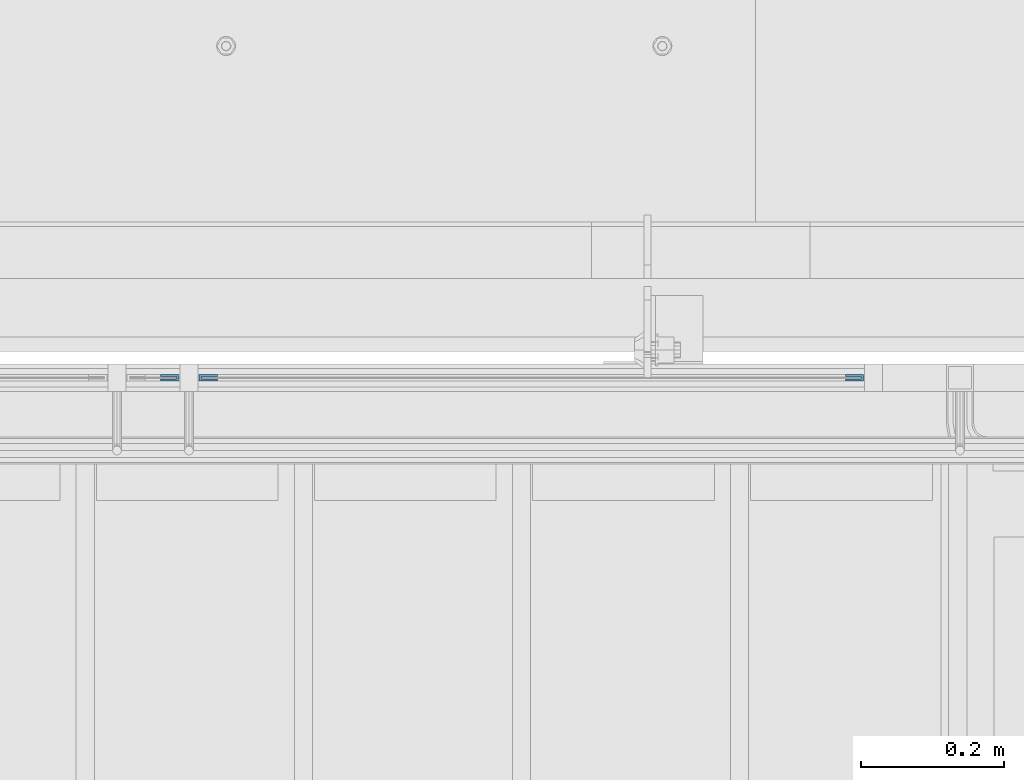
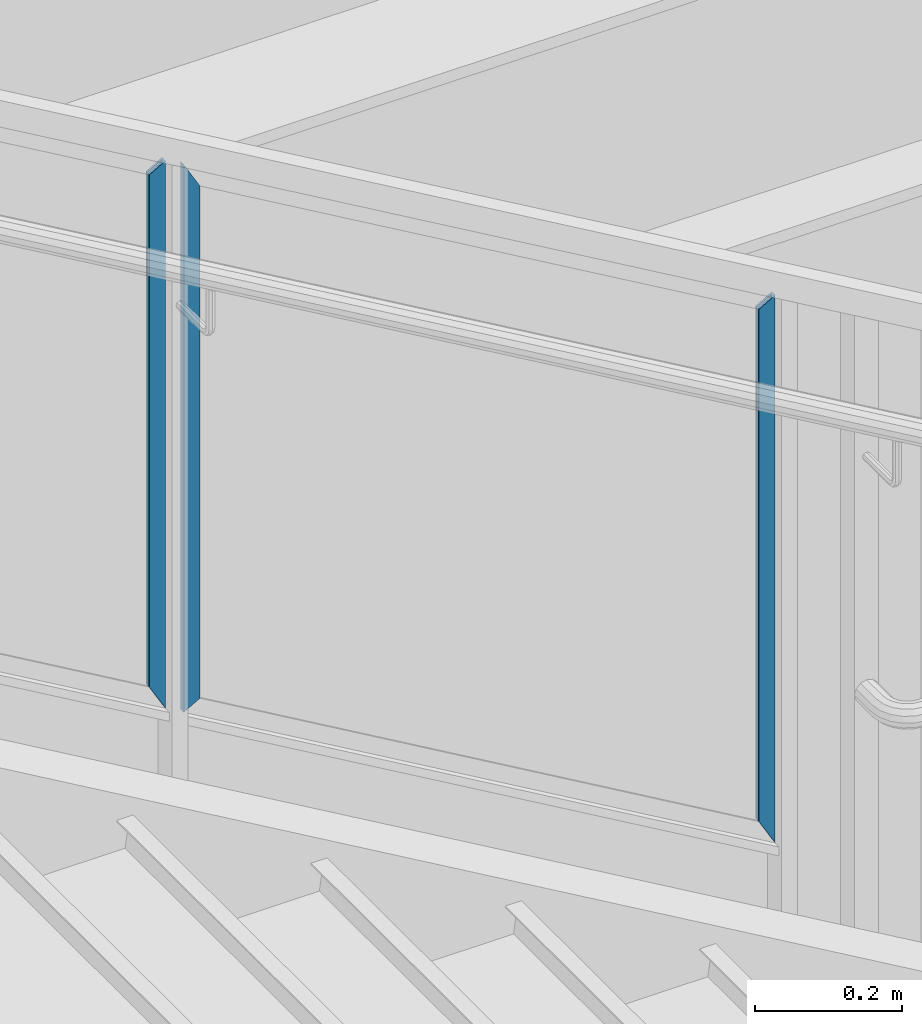
# One storey, part 945 of 1179: 3 beams, 1 element without a shape of its own.
"""IFC2X3 building model written with IfcOpenShell, lengths in millimetres."""

from ifc_helpers import new_model, si_unit, frame, origin_with_axes, place, context, subcontext, project, spatial, faceted_brep, material, type_object, element, aggregate, save


model = new_model("IFC2X3")

# Units and contexts
model_context = context("Model", 3, precision=1e-05, world=origin_with_axes())
body_context = subcontext(model_context, "Body", "Model", "MODEL_VIEW")
ifc_project = project(units=[si_unit("LENGTHUNIT", "METRE", prefix="MILLI"), si_unit("AREAUNIT", "SQUARE_METRE"), si_unit("VOLUMEUNIT", "CUBIC_METRE"), si_unit("MASSUNIT", "GRAM", prefix="KILO"), si_unit("TIMEUNIT", "SECOND"), si_unit("PLANEANGLEUNIT", "RADIAN"), si_unit("SOLIDANGLEUNIT", "STERADIAN"), si_unit("THERMODYNAMICTEMPERATUREUNIT", "DEGREE_CELSIUS"), si_unit("LUMINOUSINTENSITYUNIT", "LUMEN")], contexts=[model_context])

# Site, building, storey
site_placement = place(None, origin_with_axes())
site = spatial("IfcSite", under=ifc_project, at=site_placement, CompositionType="ELEMENT")
building_placement = place(site_placement, origin_with_axes())
building = spatial("IfcBuilding", under=site, at=building_placement, Name="Undefined", CompositionType="ELEMENT")
storey_placement = place(building_placement, origin_with_axes())
storey = spatial("IfcBuildingStorey", under=building, at=storey_placement, Name="Undefined", CompositionType="ELEMENT", Elevation=0.0)

# Assembly, beams
assembly_placement = place(storey_placement, origin_with_axes())
assembly = element("IfcElementAssembly", 1, at=assembly_placement, inside=storey, Name="GUARDRAIL", AssemblyPlace="NOTDEFINED", PredefinedType="RIGID_FRAME")
ifc_material = material(Name="STEEL/BUY-OUT")
beam_type = type_object("IfcBeamType", PredefinedType="NOTDEFINED")
beam_1_placement = place(assembly_placement, frame((21806.4291677555, 41062.2751647691, 7583.72787206943), z_axis=(0.0, 0.0, -1.0), x_axis=(-1.0, 0.0, 0.0)))
beam_1 = element("IfcBeam", 2, at=beam_1_placement, type_object=beam_type, material=ifc_material, Name="U-EDGE", context=body_context, shape_type="Brep", body=[
    faceted_brep([(0.0, 1.58750000000146, -409.70316637002), (0.0, -1.58750000000146, -409.70316637002), (0.0, -1.58750000000146, 440.23000490029), (0.0, 1.58750000000146, 440.23000490029), (22.2249999999658, 1.58750000000146, -448.397713730088), (22.2249999999658, 1.58750000000146, 452.99537478299), (22.2249999999658, 4.76249999999709, -448.397713730088), (22.2249999999658, 4.76249999999709, 452.99537478299), (-6.54836185276508e-11, 4.76249999999709, -409.703166369906), (-6.54836185276508e-11, 4.76249999999709, 440.230004900252), (-6.54836185276508e-11, 7.9375, -409.703166369906), (-6.54836185276508e-11, 7.9375, 440.230004900252), (25.3999999999687, 7.9375, -453.925506210106), (25.3999999999687, 7.9375, 454.819), (25.3999999999687, -1.58750000000146, -453.925506210106), (25.3999999999687, -1.58750000000146, 454.819)], [[[0, 1, 2, 3]], [[4, 0, 3, 5]], [[6, 4, 5, 7]], [[8, 6, 7, 9]], [[10, 8, 9, 11]], [[12, 10, 11, 13]], [[14, 12, 13, 15]], [[11, 9, 7, 5, 3, 2, 15, 13]], [[1, 14, 15, 2]], [[0, 4, 6, 8, 10, 12, 14, 1]]]),
])
beam_2_placement = place(assembly_placement, frame((22683.7875016497, 41062.2751647691, 7044.68317677574), z_axis=(0.0, 0.0, -1.0), x_axis=(1.0, 0.0, 0.0)))
beam_2 = element("IfcBeam", 3, at=beam_2_placement, type_object=beam_type, material=ifc_material, Name="U-EDGE", context=body_context, shape_type="Brep", body=[
    faceted_brep([(4.52637323178351e-08, -4.76249999999709, -436.955500968707), (4.52637323178351e-08, -7.9375, -436.955500968707), (4.52637323178351e-08, -7.9375, 412.977775342115), (4.52637323178351e-08, -4.76249999999709, 412.977775342115), (22.2250000226304, -4.76249999999709, -449.720881550838), (22.2250000226304, -4.76249999999709, 451.672221403634), (22.2250000226304, -1.58750000000146, -449.720881550838), (22.2250000226304, -1.58750000000146, 451.672221403634), (0.0, -1.58750000000146, -436.955500942709), (0.0, -1.58750000000146, 412.977775263309), (0.0, 1.58750000000146, -436.955500942709), (0.0, 1.58750000000146, 412.97777526331), (25.4000000226333, 1.58750000000146, -451.544507350142), (25.4000000226333, 1.58750000000146, 457.2), (25.4000000226333, -7.9375, -451.544507350142), (25.4000000226333, -7.9375, 457.2)], [[[0, 1, 2, 3]], [[4, 0, 3, 5]], [[6, 4, 5, 7]], [[8, 6, 7, 9]], [[10, 8, 9, 11]], [[12, 10, 11, 13]], [[14, 12, 13, 15]], [[11, 9, 7, 5, 3, 2, 15, 13]], [[1, 14, 15, 2]], [[0, 4, 6, 8, 10, 12, 14, 1]]]),
])
beam_3_placement = place(assembly_placement, frame((21727.0541677354, 41062.2751647691, 7602.77762091297), z_axis=(0.0, 0.0, -1.0), x_axis=(1.0, 0.0, 0.0)))
beam_3 = element("IfcBeam", 4, at=beam_3_placement, type_object=beam_type, material=ifc_material, Name="U-EDGE", context=body_context, shape_type="Brep", body=[
    faceted_brep([(4.52637323178351e-08, -4.76249999999709, -436.955500968707), (4.52637323178351e-08, -7.9375, -436.955500968707), (4.52637323178351e-08, -7.9375, 412.977775342115), (4.52637323178351e-08, -4.76249999999709, 412.977775342115), (22.2250000226304, -4.76249999999709, -449.720881550838), (22.2250000226304, -4.76249999999709, 451.672221403634), (22.2250000226304, -1.58750000000146, -449.720881550838), (22.2250000226304, -1.58750000000146, 451.672221403634), (0.0, -1.58750000000146, -436.955500942709), (0.0, -1.58750000000146, 412.977775263309), (0.0, 1.58750000000146, -436.955500942709), (0.0, 1.58750000000146, 412.97777526331), (25.4000000226333, 1.58750000000146, -451.544507350142), (25.4000000226333, 1.58750000000146, 457.2), (25.4000000226333, -7.9375, -451.544507350142), (25.4000000226333, -7.9375, 457.2)], [[[0, 1, 2, 3]], [[4, 0, 3, 5]], [[6, 4, 5, 7]], [[8, 6, 7, 9]], [[10, 8, 9, 11]], [[12, 10, 11, 13]], [[14, 12, 13, 15]], [[11, 9, 7, 5, 3, 2, 15, 13]], [[1, 14, 15, 2]], [[0, 4, 6, 8, 10, 12, 14, 1]]]),
])
aggregate(assembly, [beam_1, beam_2, beam_3])

save(model, "model.ifc")
